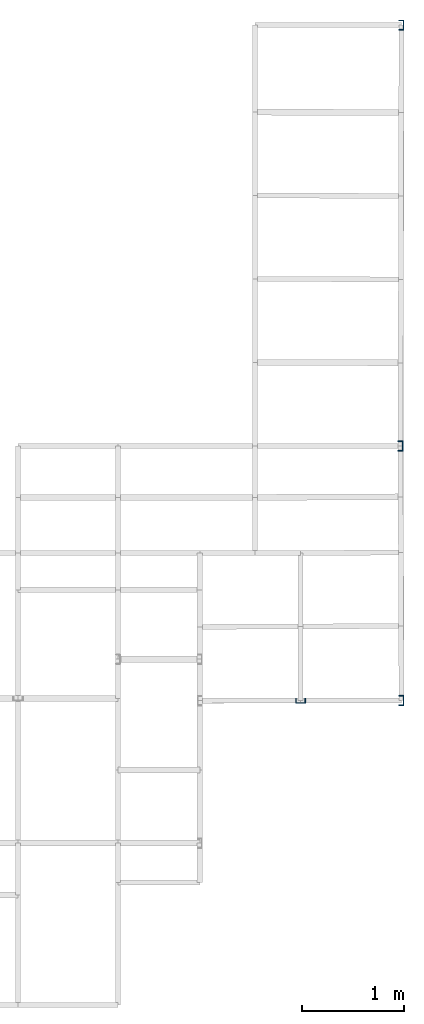
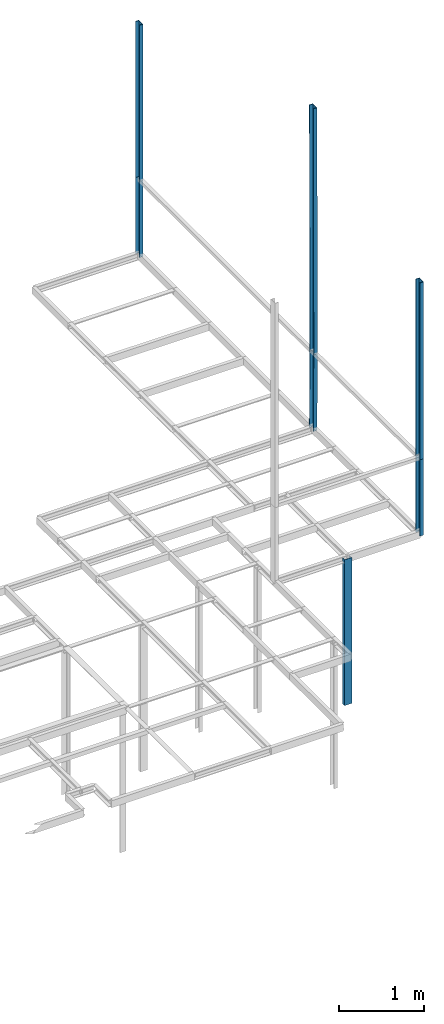
# Not in any storey, part 2 of 7: 7 columns.
"""IFC2X3 model written with IfcOpenShell, lengths in centimetres."""

from ifc_helpers import new_model, si_unit, frame, origin_with_axes, origin_2d_with_axis, place, context, project, u_section, extrude, material, element, save


model = new_model("IFC2X3")

# Units and contexts
model_context = context("Model", 3, precision=1e-05, world=origin_with_axes())
plan_context = context("Plan", 3, precision=1e-05, world=origin_with_axes())
ifc_project = project(units=[si_unit("LENGTHUNIT", "METRE", prefix="CENTI"), si_unit("AREAUNIT", "SQUARE_METRE", prefix="CENTI"), si_unit("VOLUMEUNIT", "CUBIC_METRE", prefix="CENTI"), si_unit("PLANEANGLEUNIT", "RADIAN"), si_unit("SOLIDANGLEUNIT", "STERADIAN"), si_unit("MASSUNIT", "GRAM"), si_unit("TIMEUNIT", "SECOND"), si_unit("THERMODYNAMICTEMPERATUREUNIT", "DEGREE_CELSIUS"), si_unit("LUMINOUSINTENSITYUNIT", "LUMEN")], contexts=[model_context, plan_context])

# Columns
ifc_material = material()
column_1_placement = place(None, frame((389.800018310547, 130.5, 0.0), z_axis=(0.0, 0.0, 1.0), x_axis=(0.0, 1.0, 0.0)))
element("IfcColumn", 1, at=column_1_placement, material=ifc_material, Name="UPN - de ala Pilar:UPN 100", context=model_context, shape_type="SweptSolid", body=[
    extrude(u_section(Depth=10.0, FlangeWidth=5.0, WebThickness=0.6, FlangeThickness=0.85, FilletRadius=0.0, EdgeRadius=0.0, FlangeSlope=0.0, CentreOfGravityInX=0.0, at=origin_2d_with_axis()), origin_with_axes(), (0.0, 0.0, 1.0), 210.0),
])
column_2_placement = place(None, frame((488.5, 791.700012207031, 210.0), z_axis=(0.0, 0.0, 1.0), x_axis=(-1.0, 0.0, 0.0)))
element("IfcColumn", 2, at=column_2_placement, material=ifc_material, Name="UPN - de ala Pilar:UPN 100", context=model_context, shape_type="SweptSolid", body=[
    extrude(u_section(Depth=10.0, FlangeWidth=5.0, WebThickness=0.6, FlangeThickness=0.85, FilletRadius=0.0, EdgeRadius=0.0, FlangeSlope=0.0, CentreOfGravityInX=0.0, at=origin_2d_with_axis()), origin_with_axes(), (0.0, 0.0, 1.0), 110.0),
])
column_3_placement = place(None, frame((487.5, 379.800018310547, 210.0), z_axis=(0.004545407589, 0.0, 0.999989669582), x_axis=(-0.999989688396, 0.0, 0.00454540737)))
element("IfcColumn", 3, at=column_3_placement, material=ifc_material, Name="UPN - de ala Pilar:UPN 100", context=model_context, shape_type="SweptSolid", body=[
    extrude(u_section(Depth=10.0, FlangeWidth=5.0, WebThickness=0.6, FlangeThickness=0.85, FilletRadius=0.0, EdgeRadius=0.0, FlangeSlope=0.0, CentreOfGravityInX=0.0, at=origin_2d_with_axis()), origin_with_axes(), (0.0, 0.0, 1.0), 110.001136357767),
])
column_4_placement = place(None, frame((488.5, 130.5, 210.0), z_axis=(0.0, 0.0, 1.0), x_axis=(-1.0, 0.0, 0.0)))
element("IfcColumn", 4, at=column_4_placement, material=ifc_material, Name="UPN - de ala Pilar:UPN 100", context=model_context, shape_type="SweptSolid", body=[
    extrude(u_section(Depth=10.0, FlangeWidth=5.0, WebThickness=0.6, FlangeThickness=0.85, FilletRadius=0.0, EdgeRadius=0.0, FlangeSlope=0.0, CentreOfGravityInX=0.0, at=origin_2d_with_axis()), origin_with_axes(), (0.0, 0.0, 1.0), 110.0),
])
column_5_placement = place(None, frame((488.5, 791.700012207031, 320.0), z_axis=(0.0, 0.0, 1.0), x_axis=(-1.0, 0.0, 0.0)))
element("IfcColumn", 5, at=column_5_placement, material=ifc_material, Name="UPN - de ala Pilar:UPN 100", context=model_context, shape_type="SweptSolid", body=[
    extrude(u_section(Depth=10.0, FlangeWidth=5.0, WebThickness=0.6, FlangeThickness=0.85, FilletRadius=0.0, EdgeRadius=0.0, FlangeSlope=0.0, CentreOfGravityInX=0.0, at=origin_2d_with_axis()), origin_with_axes(), (0.0, 0.0, 1.0), 224.5),
])
column_6_placement = place(None, frame((488.0, 379.800018310547, 320.0), z_axis=(-0.001410435833, 0.0, 0.999999005335), x_axis=(-0.999998986721, 0.0, -0.001410435885)))
element("IfcColumn", 6, at=column_6_placement, material=ifc_material, Name="UPN - de ala Pilar:UPN 100", context=model_context, shape_type="SweptSolid", body=[
    extrude(u_section(Depth=10.0, FlangeWidth=5.0, WebThickness=0.6, FlangeThickness=0.85, FilletRadius=0.0, EdgeRadius=0.0, FlangeSlope=0.0, CentreOfGravityInX=0.0, at=origin_2d_with_axis()), origin_with_axes(), (0.0, 0.0, 1.0), 354.500352609134),
])
column_7_placement = place(None, frame((488.5, 130.5, 320.0), z_axis=(0.0, 0.0, 1.0), x_axis=(-1.0, 0.0, 0.0)))
element("IfcColumn", 7, at=column_7_placement, material=ifc_material, Name="UPN - de ala Pilar:UPN 100", context=model_context, shape_type="SweptSolid", body=[
    extrude(u_section(Depth=10.0, FlangeWidth=5.0, WebThickness=0.6, FlangeThickness=0.85, FilletRadius=0.0, EdgeRadius=0.0, FlangeSlope=0.0, CentreOfGravityInX=0.0, at=origin_2d_with_axis()), origin_with_axes(), (0.0, 0.0, 1.0), 254.5),
])

save(model, "model.ifc")
